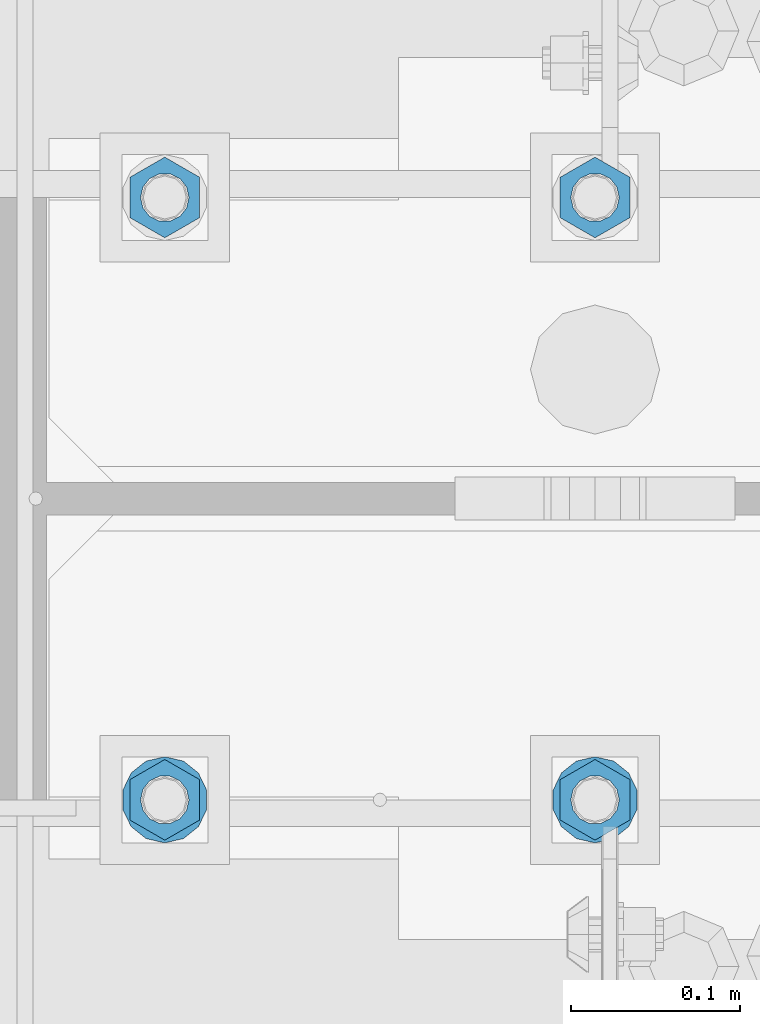
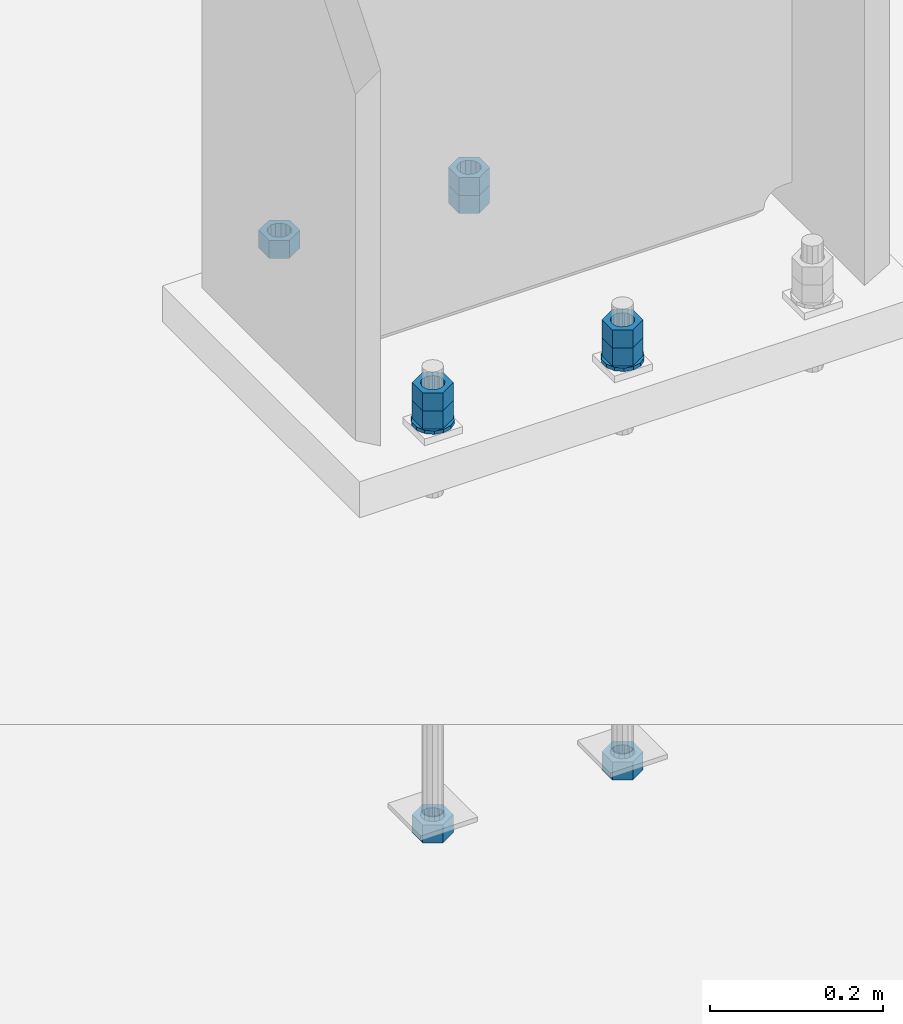
# One storey, part 1016 of 1763: 11 columns, 1 element without a shape of its own.
"""IFC2X3 building model written with IfcOpenShell, lengths in millimetres."""

from ifc_helpers import new_model, si_unit, frame, origin_with_axes, place, context, subcontext, project, spatial, faceted_brep, material, type_object, element, aggregate, save


model = new_model("IFC2X3")

# Units and contexts
model_context = context("Model", 3, precision=1e-05, world=origin_with_axes())
body_context = subcontext(model_context, "Body", "Model", "MODEL_VIEW")
ifc_project = project(units=[si_unit("LENGTHUNIT", "METRE", prefix="MILLI"), si_unit("AREAUNIT", "SQUARE_METRE"), si_unit("VOLUMEUNIT", "CUBIC_METRE"), si_unit("MASSUNIT", "GRAM", prefix="KILO"), si_unit("TIMEUNIT", "SECOND"), si_unit("PLANEANGLEUNIT", "RADIAN"), si_unit("SOLIDANGLEUNIT", "STERADIAN"), si_unit("THERMODYNAMICTEMPERATUREUNIT", "DEGREE_CELSIUS"), si_unit("LUMINOUSINTENSITYUNIT", "LUMEN")], contexts=[model_context])

# Site, building, storey
site_placement = place(None, origin_with_axes())
site = spatial("IfcSite", under=ifc_project, at=site_placement, CompositionType="ELEMENT")
building_placement = place(site_placement, origin_with_axes())
building = spatial("IfcBuilding", under=site, at=building_placement, Name="Undefined", CompositionType="ELEMENT")
storey_placement = place(building_placement, origin_with_axes())
storey = spatial("IfcBuildingStorey", under=building, at=storey_placement, Name="Undefined", CompositionType="ELEMENT", Elevation=0.0)

# Assembly, columns
assembly_placement = place(storey_placement, origin_with_axes())
assembly = element("IfcElementAssembly", 1, at=assembly_placement, inside=storey, Name="TEMPLATE", AssemblyPlace="NOTDEFINED", PredefinedType="RIGID_FRAME")
ifc_material_1 = material(Name="STEEL/A563")
column_type_1 = type_object("IfcColumnType", Name="1_HEAVY_HEX_NUT", PredefinedType="NOTDEFINED")
column_1_placement = place(assembly_placement, frame((-87375.4372736983, 51943.0, -150.812500000016), z_axis=(1.0, 0.0, 0.0), x_axis=(0.0, 0.0, -1.0)))
column_1 = element("IfcColumn", 2, at=column_1_placement, type_object=column_type_1, material=ifc_material_1, Name="NUT", ObjectType="1_HEAVY_HEX_NUT", context=body_context, shape_type="Brep", body=[
    faceted_brep([(0.0, -23.8099994659424, 0.0), (0.0, -11.9099998474121, -20.6200008392334), (25.4, -11.9099998474121, -20.6200008392334), (25.4, -23.8099994659424, 0.0), (0.0, 11.9099998474121, -20.6200008392334), (25.4, 11.9099998474121, -20.6200008392334), (0.0, 23.8099994659424, 0.0), (25.4, 23.8099994659424, 0.0), (0.0, 11.9099998474121, 20.6200008392334), (25.4, 11.9099998474121, 20.6200008392334), (0.0, -11.9099998474121, 20.6200008392334), (25.4, -11.9099998474121, 20.6200008392334), (0.0, 0.0, 14.289999961853), (0.0, 6.20019861543551, 12.8748450879575), (25.4, 6.20019861543551, 12.8748450879502), (25.4, 0.0, 14.289999961853), (0.0, 11.1723718546418, 8.90966924477834), (25.4, 11.1723718546418, 8.90966924477834), (0.0, 13.9317198278877, 3.17982413774735), (25.4, 13.9317198278877, 3.17982413774007), (0.0, 13.9317198278877, -3.17982413774735), (25.4, 13.9317198278877, -3.17982413774007), (0.0, 11.1723718546418, -8.90966924477834), (25.4, 11.1723718546418, -8.90966924477834), (0.0, 6.20019861543551, -12.8748450879575), (25.4, 6.20019861543551, -12.8748450879502), (0.0, 0.0, -14.289999961853), (25.4, 0.0, -14.289999961853), (0.0, -6.20019861543551, -12.8748450879575), (25.4, -6.20019861543551, -12.8748450879502), (0.0, -11.1723718546418, -8.90966924477834), (25.4, -11.1723718546418, -8.90966924477834), (0.0, -13.9317198278877, -3.17982413774735), (25.4, -13.9317198278877, -3.17982413774007), (0.0, -13.9317198278877, 3.17982413774735), (25.4, -13.9317198278877, 3.17982413774007), (0.0, -11.1723718546418, 8.90966924477834), (25.4, -11.1723718546418, 8.90966924477834), (0.0, -6.20019861543551, 12.8748450879575), (25.4, -6.20019861543551, 12.8748450879502)], [[[0, 1, 2, 3]], [[1, 4, 5, 2]], [[4, 6, 7, 5]], [[6, 8, 9, 7]], [[8, 10, 11, 9]], [[10, 0, 3, 11]], [[12, 13, 14, 15]], [[13, 16, 17, 14]], [[16, 18, 19, 17]], [[18, 20, 21, 19]], [[20, 22, 23, 21]], [[22, 24, 25, 23]], [[24, 26, 27, 25]], [[26, 28, 29, 27]], [[28, 30, 31, 29]], [[30, 32, 33, 31]], [[32, 34, 35, 33]], [[34, 36, 37, 35]], [[36, 38, 39, 37]], [[38, 12, 15, 39]], [[5, 7, 9, 11, 3, 2], [17, 19, 21, 23, 25, 27, 29, 31, 33, 35, 37, 39, 15, 14]], [[10, 8, 6, 4, 1, 0], [38, 36, 34, 32, 30, 28, 26, 24, 22, 20, 18, 16, 13, 12]]]),
])
column_2_placement = place(assembly_placement, frame((-87375.4372736983, 52298.6, -150.812500000016), z_axis=(-1.0, 0.0, 0.0), x_axis=(0.0, 0.0, -1.0)))
column_2 = element("IfcColumn", 3, at=column_2_placement, type_object=column_type_1, material=ifc_material_1, Name="NUT", ObjectType="1_HEAVY_HEX_NUT", context=body_context, shape_type="Brep", body=[
    faceted_brep([(0.0, -23.8099994659424, 0.0), (0.0, -11.9099998474121, -20.6200008392334), (25.4, -11.9099998474121, -20.6200008392334), (25.4, -23.8099994659424, 0.0), (0.0, 11.9099998474121, -20.6200008392334), (25.4, 11.9099998474121, -20.6200008392334), (0.0, 23.8099994659424, 0.0), (25.4, 23.8099994659424, 0.0), (0.0, 11.9099998474121, 20.6200008392334), (25.4, 11.9099998474121, 20.6200008392334), (0.0, -11.9099998474121, 20.6200008392334), (25.4, -11.9099998474121, 20.6200008392334), (0.0, 0.0, 14.289999961853), (0.0, 6.20019861543551, 12.8748450879575), (25.4, 6.20019861543551, 12.8748450879502), (25.4, 0.0, 14.289999961853), (0.0, 11.1723718546418, 8.90966924477834), (25.4, 11.1723718546418, 8.90966924477834), (0.0, 13.9317198278877, 3.17982413774735), (25.4, 13.9317198278877, 3.17982413774007), (0.0, 13.9317198278877, -3.17982413774735), (25.4, 13.9317198278877, -3.17982413774007), (0.0, 11.1723718546418, -8.90966924477834), (25.4, 11.1723718546418, -8.90966924477834), (0.0, 6.20019861543551, -12.8748450879575), (25.4, 6.20019861543551, -12.8748450879502), (0.0, 0.0, -14.289999961853), (25.4, 0.0, -14.289999961853), (0.0, -6.20019861543551, -12.8748450879575), (25.4, -6.20019861543551, -12.8748450879502), (0.0, -11.1723718546418, -8.90966924477834), (25.4, -11.1723718546418, -8.90966924477834), (0.0, -13.9317198278877, -3.17982413774735), (25.4, -13.9317198278877, -3.17982413774007), (0.0, -13.9317198278877, 3.17982413774735), (25.4, -13.9317198278877, 3.17982413774007), (0.0, -11.1723718546418, 8.90966924477834), (25.4, -11.1723718546418, 8.90966924477834), (0.0, -6.20019861543551, 12.8748450879575), (25.4, -6.20019861543551, 12.8748450879502)], [[[0, 1, 2, 3]], [[1, 4, 5, 2]], [[4, 6, 7, 5]], [[6, 8, 9, 7]], [[8, 10, 11, 9]], [[10, 0, 3, 11]], [[12, 13, 14, 15]], [[13, 16, 17, 14]], [[16, 18, 19, 17]], [[18, 20, 21, 19]], [[20, 22, 23, 21]], [[22, 24, 25, 23]], [[24, 26, 27, 25]], [[26, 28, 29, 27]], [[28, 30, 31, 29]], [[30, 32, 33, 31]], [[32, 34, 35, 33]], [[34, 36, 37, 35]], [[36, 38, 39, 37]], [[38, 12, 15, 39]], [[5, 7, 9, 11, 3, 2], [17, 19, 21, 23, 25, 27, 29, 31, 33, 35, 37, 39, 15, 14]], [[10, 8, 6, 4, 1, 0], [38, 36, 34, 32, 30, 28, 26, 24, 22, 20, 18, 16, 13, 12]]]),
])
column_3_placement = place(assembly_placement, frame((-87629.4372736983, 51943.0, -150.812500000016), z_axis=(1.0, 0.0, 0.0), x_axis=(0.0, 0.0, -1.0)))
column_3 = element("IfcColumn", 4, at=column_3_placement, type_object=column_type_1, material=ifc_material_1, Name="NUT", ObjectType="1_HEAVY_HEX_NUT", context=body_context, shape_type="Brep", body=[
    faceted_brep([(0.0, -23.8099994659424, 0.0), (0.0, -11.9099998474121, -20.6200008392334), (25.4, -11.9099998474121, -20.6200008392334), (25.4, -23.8099994659424, 0.0), (0.0, 11.9099998474121, -20.6200008392334), (25.4, 11.9099998474121, -20.6200008392334), (0.0, 23.8099994659424, 0.0), (25.4, 23.8099994659424, 0.0), (0.0, 11.9099998474121, 20.6200008392334), (25.4, 11.9099998474121, 20.6200008392334), (0.0, -11.9099998474121, 20.6200008392334), (25.4, -11.9099998474121, 20.6200008392334), (0.0, 0.0, 14.289999961853), (0.0, 6.20019861543551, 12.8748450879575), (25.4, 6.20019861543551, 12.8748450879502), (25.4, 0.0, 14.289999961853), (0.0, 11.1723718546418, 8.90966924477834), (25.4, 11.1723718546418, 8.90966924477834), (0.0, 13.9317198278877, 3.17982413774735), (25.4, 13.9317198278877, 3.17982413774007), (0.0, 13.9317198278877, -3.17982413774735), (25.4, 13.9317198278877, -3.17982413774007), (0.0, 11.1723718546418, -8.90966924477834), (25.4, 11.1723718546418, -8.90966924477834), (0.0, 6.20019861543551, -12.8748450879575), (25.4, 6.20019861543551, -12.8748450879502), (0.0, 0.0, -14.289999961853), (25.4, 0.0, -14.289999961853), (0.0, -6.20019861543551, -12.8748450879575), (25.4, -6.20019861543551, -12.8748450879502), (0.0, -11.1723718546418, -8.90966924477834), (25.4, -11.1723718546418, -8.90966924477834), (0.0, -13.9317198278877, -3.17982413774735), (25.4, -13.9317198278877, -3.17982413774007), (0.0, -13.9317198278877, 3.17982413774735), (25.4, -13.9317198278877, 3.17982413774007), (0.0, -11.1723718546418, 8.90966924477834), (25.4, -11.1723718546418, 8.90966924477834), (0.0, -6.20019861543551, 12.8748450879575), (25.4, -6.20019861543551, 12.8748450879502)], [[[0, 1, 2, 3]], [[1, 4, 5, 2]], [[4, 6, 7, 5]], [[6, 8, 9, 7]], [[8, 10, 11, 9]], [[10, 0, 3, 11]], [[12, 13, 14, 15]], [[13, 16, 17, 14]], [[16, 18, 19, 17]], [[18, 20, 21, 19]], [[20, 22, 23, 21]], [[22, 24, 25, 23]], [[24, 26, 27, 25]], [[26, 28, 29, 27]], [[28, 30, 31, 29]], [[30, 32, 33, 31]], [[32, 34, 35, 33]], [[34, 36, 37, 35]], [[36, 38, 39, 37]], [[38, 12, 15, 39]], [[5, 7, 9, 11, 3, 2], [17, 19, 21, 23, 25, 27, 29, 31, 33, 35, 37, 39, 15, 14]], [[10, 8, 6, 4, 1, 0], [38, 36, 34, 32, 30, 28, 26, 24, 22, 20, 18, 16, 13, 12]]]),
])
column_4_placement = place(assembly_placement, frame((-87629.4372736983, 52298.6, -150.812500000016), z_axis=(-1.0, 0.0, 0.0), x_axis=(0.0, 0.0, -1.0)))
column_4 = element("IfcColumn", 5, at=column_4_placement, type_object=column_type_1, material=ifc_material_1, Name="NUT", ObjectType="1_HEAVY_HEX_NUT", context=body_context, shape_type="Brep", body=[
    faceted_brep([(0.0, -23.8099994659424, 0.0), (0.0, -11.9099998474121, -20.6200008392334), (25.4, -11.9099998474121, -20.6200008392334), (25.4, -23.8099994659424, 0.0), (0.0, 11.9099998474121, -20.6200008392334), (25.4, 11.9099998474121, -20.6200008392334), (0.0, 23.8099994659424, 0.0), (25.4, 23.8099994659424, 0.0), (0.0, 11.9099998474121, 20.6200008392334), (25.4, 11.9099998474121, 20.6200008392334), (0.0, -11.9099998474121, 20.6200008392334), (25.4, -11.9099998474121, 20.6200008392334), (0.0, 0.0, 14.289999961853), (0.0, 6.20019861543551, 12.8748450879575), (25.4, 6.20019861543551, 12.8748450879502), (25.4, 0.0, 14.289999961853), (0.0, 11.1723718546418, 8.90966924477834), (25.4, 11.1723718546418, 8.90966924477834), (0.0, 13.9317198278877, 3.17982413774735), (25.4, 13.9317198278877, 3.17982413774007), (0.0, 13.9317198278877, -3.17982413774735), (25.4, 13.9317198278877, -3.17982413774007), (0.0, 11.1723718546418, -8.90966924477834), (25.4, 11.1723718546418, -8.90966924477834), (0.0, 6.20019861543551, -12.8748450879575), (25.4, 6.20019861543551, -12.8748450879502), (0.0, 0.0, -14.289999961853), (25.4, 0.0, -14.289999961853), (0.0, -6.20019861543551, -12.8748450879575), (25.4, -6.20019861543551, -12.8748450879502), (0.0, -11.1723718546418, -8.90966924477834), (25.4, -11.1723718546418, -8.90966924477834), (0.0, -13.9317198278877, -3.17982413774735), (25.4, -13.9317198278877, -3.17982413774007), (0.0, -13.9317198278877, 3.17982413774735), (25.4, -13.9317198278877, 3.17982413774007), (0.0, -11.1723718546418, 8.90966924477834), (25.4, -11.1723718546418, 8.90966924477834), (0.0, -6.20019861543551, 12.8748450879575), (25.4, -6.20019861543551, 12.8748450879502)], [[[0, 1, 2, 3]], [[1, 4, 5, 2]], [[4, 6, 7, 5]], [[6, 8, 9, 7]], [[8, 10, 11, 9]], [[10, 0, 3, 11]], [[12, 13, 14, 15]], [[13, 16, 17, 14]], [[16, 18, 19, 17]], [[18, 20, 21, 19]], [[20, 22, 23, 21]], [[22, 24, 25, 23]], [[24, 26, 27, 25]], [[26, 28, 29, 27]], [[28, 30, 31, 29]], [[30, 32, 33, 31]], [[32, 34, 35, 33]], [[34, 36, 37, 35]], [[36, 38, 39, 37]], [[38, 12, 15, 39]], [[5, 7, 9, 11, 3, 2], [17, 19, 21, 23, 25, 27, 29, 31, 33, 35, 37, 39, 15, 14]], [[10, 8, 6, 4, 1, 0], [38, 36, 34, 32, 30, 28, 26, 24, 22, 20, 18, 16, 13, 12]]]),
])
column_5_placement = place(assembly_placement, frame((-87375.4372736983, 51943.0, -176.212500000016), z_axis=(1.0, 0.0, 0.0), x_axis=(0.0, 0.0, -1.0)))
column_5 = element("IfcColumn", 6, at=column_5_placement, type_object=column_type_1, material=ifc_material_1, Name="NUT", ObjectType="1_HEAVY_HEX_NUT", context=body_context, shape_type="Brep", body=[
    faceted_brep([(0.0, -23.8099994659424, 0.0), (0.0, -11.9099998474121, -20.6200008392334), (25.4, -11.9099998474121, -20.6200008392334), (25.4, -23.8099994659424, 0.0), (0.0, 11.9099998474121, -20.6200008392334), (25.4, 11.9099998474121, -20.6200008392334), (0.0, 23.8099994659424, 0.0), (25.4, 23.8099994659424, 0.0), (0.0, 11.9099998474121, 20.6200008392334), (25.4, 11.9099998474121, 20.6200008392334), (0.0, -11.9099998474121, 20.6200008392334), (25.4, -11.9099998474121, 20.6200008392334), (0.0, 0.0, 14.289999961853), (0.0, 6.20019861543551, 12.8748450879575), (25.4, 6.20019861543551, 12.8748450879502), (25.4, 0.0, 14.289999961853), (0.0, 11.1723718546418, 8.90966924477834), (25.4, 11.1723718546418, 8.90966924477834), (0.0, 13.9317198278877, 3.17982413774735), (25.4, 13.9317198278877, 3.17982413774007), (0.0, 13.9317198278877, -3.17982413774735), (25.4, 13.9317198278877, -3.17982413774007), (0.0, 11.1723718546418, -8.90966924477834), (25.4, 11.1723718546418, -8.90966924477834), (0.0, 6.20019861543551, -12.8748450879575), (25.4, 6.20019861543551, -12.8748450879502), (0.0, 0.0, -14.289999961853), (25.4, 0.0, -14.289999961853), (0.0, -6.20019861543551, -12.8748450879575), (25.4, -6.20019861543551, -12.8748450879502), (0.0, -11.1723718546418, -8.90966924477834), (25.4, -11.1723718546418, -8.90966924477834), (0.0, -13.9317198278877, -3.17982413774735), (25.4, -13.9317198278877, -3.17982413774007), (0.0, -13.9317198278877, 3.17982413774735), (25.4, -13.9317198278877, 3.17982413774007), (0.0, -11.1723718546418, 8.90966924477834), (25.4, -11.1723718546418, 8.90966924477834), (0.0, -6.20019861543551, 12.8748450879575), (25.4, -6.20019861543551, 12.8748450879502)], [[[0, 1, 2, 3]], [[1, 4, 5, 2]], [[4, 6, 7, 5]], [[6, 8, 9, 7]], [[8, 10, 11, 9]], [[10, 0, 3, 11]], [[12, 13, 14, 15]], [[13, 16, 17, 14]], [[16, 18, 19, 17]], [[18, 20, 21, 19]], [[20, 22, 23, 21]], [[22, 24, 25, 23]], [[24, 26, 27, 25]], [[26, 28, 29, 27]], [[28, 30, 31, 29]], [[30, 32, 33, 31]], [[32, 34, 35, 33]], [[34, 36, 37, 35]], [[36, 38, 39, 37]], [[38, 12, 15, 39]], [[5, 7, 9, 11, 3, 2], [17, 19, 21, 23, 25, 27, 29, 31, 33, 35, 37, 39, 15, 14]], [[10, 8, 6, 4, 1, 0], [38, 36, 34, 32, 30, 28, 26, 24, 22, 20, 18, 16, 13, 12]]]),
])
column_6_placement = place(assembly_placement, frame((-87375.4372736983, 51943.0, -762.000000000016), z_axis=(1.0, 0.0, 0.0), x_axis=(0.0, 0.0, -1.0)))
column_6 = element("IfcColumn", 7, at=column_6_placement, type_object=column_type_1, material=ifc_material_1, Name="NUT", ObjectType="1_HEAVY_HEX_NUT", context=body_context, shape_type="Brep", body=[
    faceted_brep([(0.0, -23.8099994659424, 0.0), (0.0, -11.9099998474121, -20.6200008392334), (25.4, -11.9099998474121, -20.6200008392334), (25.4, -23.8099994659424, 0.0), (0.0, 11.9099998474121, -20.6200008392334), (25.4, 11.9099998474121, -20.6200008392334), (0.0, 23.8099994659424, 0.0), (25.4, 23.8099994659424, 0.0), (0.0, 11.9099998474121, 20.6200008392334), (25.4, 11.9099998474121, 20.6200008392334), (0.0, -11.9099998474121, 20.6200008392334), (25.4, -11.9099998474121, 20.6200008392334), (0.0, 0.0, 14.289999961853), (0.0, 6.20019861543551, 12.8748450879575), (25.4, 6.20019861543551, 12.8748450879502), (25.4, 0.0, 14.289999961853), (0.0, 11.1723718546418, 8.90966924477834), (25.4, 11.1723718546418, 8.90966924477834), (0.0, 13.9317198278877, 3.17982413774735), (25.4, 13.9317198278877, 3.17982413774007), (0.0, 13.9317198278877, -3.17982413774735), (25.4, 13.9317198278877, -3.17982413774007), (0.0, 11.1723718546418, -8.90966924477834), (25.4, 11.1723718546418, -8.90966924477834), (0.0, 6.20019861543551, -12.8748450879575), (25.4, 6.20019861543551, -12.8748450879502), (0.0, 0.0, -14.289999961853), (25.4, 0.0, -14.289999961853), (0.0, -6.20019861543551, -12.8748450879575), (25.4, -6.20019861543551, -12.8748450879502), (0.0, -11.1723718546418, -8.90966924477834), (25.4, -11.1723718546418, -8.90966924477834), (0.0, -13.9317198278877, -3.17982413774735), (25.4, -13.9317198278877, -3.17982413774007), (0.0, -13.9317198278877, 3.17982413774735), (25.4, -13.9317198278877, 3.17982413774007), (0.0, -11.1723718546418, 8.90966924477834), (25.4, -11.1723718546418, 8.90966924477834), (0.0, -6.20019861543551, 12.8748450879575), (25.4, -6.20019861543551, 12.8748450879502)], [[[0, 1, 2, 3]], [[1, 4, 5, 2]], [[4, 6, 7, 5]], [[6, 8, 9, 7]], [[8, 10, 11, 9]], [[10, 0, 3, 11]], [[12, 13, 14, 15]], [[13, 16, 17, 14]], [[16, 18, 19, 17]], [[18, 20, 21, 19]], [[20, 22, 23, 21]], [[22, 24, 25, 23]], [[24, 26, 27, 25]], [[26, 28, 29, 27]], [[28, 30, 31, 29]], [[30, 32, 33, 31]], [[32, 34, 35, 33]], [[34, 36, 37, 35]], [[36, 38, 39, 37]], [[38, 12, 15, 39]], [[5, 7, 9, 11, 3, 2], [17, 19, 21, 23, 25, 27, 29, 31, 33, 35, 37, 39, 15, 14]], [[10, 8, 6, 4, 1, 0], [38, 36, 34, 32, 30, 28, 26, 24, 22, 20, 18, 16, 13, 12]]]),
])
column_7_placement = place(assembly_placement, frame((-87375.4372736983, 52298.6, -176.212500000016), z_axis=(-1.0, 0.0, 0.0), x_axis=(0.0, 0.0, -1.0)))
column_7 = element("IfcColumn", 8, at=column_7_placement, type_object=column_type_1, material=ifc_material_1, Name="NUT", ObjectType="1_HEAVY_HEX_NUT", context=body_context, shape_type="Brep", body=[
    faceted_brep([(0.0, -23.8099994659424, 0.0), (0.0, -11.9099998474121, -20.6200008392334), (25.4, -11.9099998474121, -20.6200008392334), (25.4, -23.8099994659424, 0.0), (0.0, 11.9099998474121, -20.6200008392334), (25.4, 11.9099998474121, -20.6200008392334), (0.0, 23.8099994659424, 0.0), (25.4, 23.8099994659424, 0.0), (0.0, 11.9099998474121, 20.6200008392334), (25.4, 11.9099998474121, 20.6200008392334), (0.0, -11.9099998474121, 20.6200008392334), (25.4, -11.9099998474121, 20.6200008392334), (0.0, 0.0, 14.289999961853), (0.0, 6.20019861543551, 12.8748450879575), (25.4, 6.20019861543551, 12.8748450879502), (25.4, 0.0, 14.289999961853), (0.0, 11.1723718546418, 8.90966924477834), (25.4, 11.1723718546418, 8.90966924477834), (0.0, 13.9317198278877, 3.17982413774735), (25.4, 13.9317198278877, 3.17982413774007), (0.0, 13.9317198278877, -3.17982413774735), (25.4, 13.9317198278877, -3.17982413774007), (0.0, 11.1723718546418, -8.90966924477834), (25.4, 11.1723718546418, -8.90966924477834), (0.0, 6.20019861543551, -12.8748450879575), (25.4, 6.20019861543551, -12.8748450879502), (0.0, 0.0, -14.289999961853), (25.4, 0.0, -14.289999961853), (0.0, -6.20019861543551, -12.8748450879575), (25.4, -6.20019861543551, -12.8748450879502), (0.0, -11.1723718546418, -8.90966924477834), (25.4, -11.1723718546418, -8.90966924477834), (0.0, -13.9317198278877, -3.17982413774735), (25.4, -13.9317198278877, -3.17982413774007), (0.0, -13.9317198278877, 3.17982413774735), (25.4, -13.9317198278877, 3.17982413774007), (0.0, -11.1723718546418, 8.90966924477834), (25.4, -11.1723718546418, 8.90966924477834), (0.0, -6.20019861543551, 12.8748450879575), (25.4, -6.20019861543551, 12.8748450879502)], [[[0, 1, 2, 3]], [[1, 4, 5, 2]], [[4, 6, 7, 5]], [[6, 8, 9, 7]], [[8, 10, 11, 9]], [[10, 0, 3, 11]], [[12, 13, 14, 15]], [[13, 16, 17, 14]], [[16, 18, 19, 17]], [[18, 20, 21, 19]], [[20, 22, 23, 21]], [[22, 24, 25, 23]], [[24, 26, 27, 25]], [[26, 28, 29, 27]], [[28, 30, 31, 29]], [[30, 32, 33, 31]], [[32, 34, 35, 33]], [[34, 36, 37, 35]], [[36, 38, 39, 37]], [[38, 12, 15, 39]], [[5, 7, 9, 11, 3, 2], [17, 19, 21, 23, 25, 27, 29, 31, 33, 35, 37, 39, 15, 14]], [[10, 8, 6, 4, 1, 0], [38, 36, 34, 32, 30, 28, 26, 24, 22, 20, 18, 16, 13, 12]]]),
])
column_8_placement = place(assembly_placement, frame((-87629.4372736983, 51943.0, -176.212500000016), z_axis=(1.0, 0.0, 0.0), x_axis=(0.0, 0.0, -1.0)))
column_8 = element("IfcColumn", 9, at=column_8_placement, type_object=column_type_1, material=ifc_material_1, Name="NUT", ObjectType="1_HEAVY_HEX_NUT", context=body_context, shape_type="Brep", body=[
    faceted_brep([(0.0, -23.8099994659424, 0.0), (0.0, -11.9099998474121, -20.6200008392334), (25.4, -11.9099998474121, -20.6200008392334), (25.4, -23.8099994659424, 0.0), (0.0, 11.9099998474121, -20.6200008392334), (25.4, 11.9099998474121, -20.6200008392334), (0.0, 23.8099994659424, 0.0), (25.4, 23.8099994659424, 0.0), (0.0, 11.9099998474121, 20.6200008392334), (25.4, 11.9099998474121, 20.6200008392334), (0.0, -11.9099998474121, 20.6200008392334), (25.4, -11.9099998474121, 20.6200008392334), (0.0, 0.0, 14.289999961853), (0.0, 6.20019861543551, 12.8748450879575), (25.4, 6.20019861543551, 12.8748450879502), (25.4, 0.0, 14.289999961853), (0.0, 11.1723718546418, 8.90966924477834), (25.4, 11.1723718546418, 8.90966924477834), (0.0, 13.9317198278877, 3.17982413774735), (25.4, 13.9317198278877, 3.17982413774007), (0.0, 13.9317198278877, -3.17982413774735), (25.4, 13.9317198278877, -3.17982413774007), (0.0, 11.1723718546418, -8.90966924477834), (25.4, 11.1723718546418, -8.90966924477834), (0.0, 6.20019861543551, -12.8748450879575), (25.4, 6.20019861543551, -12.8748450879502), (0.0, 0.0, -14.289999961853), (25.4, 0.0, -14.289999961853), (0.0, -6.20019861543551, -12.8748450879575), (25.4, -6.20019861543551, -12.8748450879502), (0.0, -11.1723718546418, -8.90966924477834), (25.4, -11.1723718546418, -8.90966924477834), (0.0, -13.9317198278877, -3.17982413774735), (25.4, -13.9317198278877, -3.17982413774007), (0.0, -13.9317198278877, 3.17982413774735), (25.4, -13.9317198278877, 3.17982413774007), (0.0, -11.1723718546418, 8.90966924477834), (25.4, -11.1723718546418, 8.90966924477834), (0.0, -6.20019861543551, 12.8748450879575), (25.4, -6.20019861543551, 12.8748450879502)], [[[0, 1, 2, 3]], [[1, 4, 5, 2]], [[4, 6, 7, 5]], [[6, 8, 9, 7]], [[8, 10, 11, 9]], [[10, 0, 3, 11]], [[12, 13, 14, 15]], [[13, 16, 17, 14]], [[16, 18, 19, 17]], [[18, 20, 21, 19]], [[20, 22, 23, 21]], [[22, 24, 25, 23]], [[24, 26, 27, 25]], [[26, 28, 29, 27]], [[28, 30, 31, 29]], [[30, 32, 33, 31]], [[32, 34, 35, 33]], [[34, 36, 37, 35]], [[36, 38, 39, 37]], [[38, 12, 15, 39]], [[5, 7, 9, 11, 3, 2], [17, 19, 21, 23, 25, 27, 29, 31, 33, 35, 37, 39, 15, 14]], [[10, 8, 6, 4, 1, 0], [38, 36, 34, 32, 30, 28, 26, 24, 22, 20, 18, 16, 13, 12]]]),
])
column_9_placement = place(assembly_placement, frame((-87629.4372736983, 51943.0, -762.000000000016), z_axis=(1.0, 0.0, 0.0), x_axis=(0.0, 0.0, -1.0)))
column_9 = element("IfcColumn", 10, at=column_9_placement, type_object=column_type_1, material=ifc_material_1, Name="NUT", ObjectType="1_HEAVY_HEX_NUT", context=body_context, shape_type="Brep", body=[
    faceted_brep([(0.0, -23.8099994659424, 0.0), (0.0, -11.9099998474121, -20.6200008392334), (25.4, -11.9099998474121, -20.6200008392334), (25.4, -23.8099994659424, 0.0), (0.0, 11.9099998474121, -20.6200008392334), (25.4, 11.9099998474121, -20.6200008392334), (0.0, 23.8099994659424, 0.0), (25.4, 23.8099994659424, 0.0), (0.0, 11.9099998474121, 20.6200008392334), (25.4, 11.9099998474121, 20.6200008392334), (0.0, -11.9099998474121, 20.6200008392334), (25.4, -11.9099998474121, 20.6200008392334), (0.0, 0.0, 14.289999961853), (0.0, 6.20019861543551, 12.8748450879575), (25.4, 6.20019861543551, 12.8748450879502), (25.4, 0.0, 14.289999961853), (0.0, 11.1723718546418, 8.90966924477834), (25.4, 11.1723718546418, 8.90966924477834), (0.0, 13.9317198278877, 3.17982413774735), (25.4, 13.9317198278877, 3.17982413774007), (0.0, 13.9317198278877, -3.17982413774735), (25.4, 13.9317198278877, -3.17982413774007), (0.0, 11.1723718546418, -8.90966924477834), (25.4, 11.1723718546418, -8.90966924477834), (0.0, 6.20019861543551, -12.8748450879575), (25.4, 6.20019861543551, -12.8748450879502), (0.0, 0.0, -14.289999961853), (25.4, 0.0, -14.289999961853), (0.0, -6.20019861543551, -12.8748450879575), (25.4, -6.20019861543551, -12.8748450879502), (0.0, -11.1723718546418, -8.90966924477834), (25.4, -11.1723718546418, -8.90966924477834), (0.0, -13.9317198278877, -3.17982413774735), (25.4, -13.9317198278877, -3.17982413774007), (0.0, -13.9317198278877, 3.17982413774735), (25.4, -13.9317198278877, 3.17982413774007), (0.0, -11.1723718546418, 8.90966924477834), (25.4, -11.1723718546418, 8.90966924477834), (0.0, -6.20019861543551, 12.8748450879575), (25.4, -6.20019861543551, 12.8748450879502)], [[[0, 1, 2, 3]], [[1, 4, 5, 2]], [[4, 6, 7, 5]], [[6, 8, 9, 7]], [[8, 10, 11, 9]], [[10, 0, 3, 11]], [[12, 13, 14, 15]], [[13, 16, 17, 14]], [[16, 18, 19, 17]], [[18, 20, 21, 19]], [[20, 22, 23, 21]], [[22, 24, 25, 23]], [[24, 26, 27, 25]], [[26, 28, 29, 27]], [[28, 30, 31, 29]], [[30, 32, 33, 31]], [[32, 34, 35, 33]], [[34, 36, 37, 35]], [[36, 38, 39, 37]], [[38, 12, 15, 39]], [[5, 7, 9, 11, 3, 2], [17, 19, 21, 23, 25, 27, 29, 31, 33, 35, 37, 39, 15, 14]], [[10, 8, 6, 4, 1, 0], [38, 36, 34, 32, 30, 28, 26, 24, 22, 20, 18, 16, 13, 12]]]),
])
ifc_material_2 = material(Name="STEEL/F436")
column_type_2 = type_object("IfcColumnType", Name="1_WASHER", PredefinedType="NOTDEFINED")
column_10_placement = place(assembly_placement, frame((-87375.4372736983, 51943.0, -201.612500000016), z_axis=(1.0, 0.0, 0.0), x_axis=(0.0, 0.0, -1.0)))
column_10 = element("IfcColumn", 11, at=column_10_placement, type_object=column_type_2, material=ifc_material_2, Name="WASHER", ObjectType="1_WASHER", context=body_context, shape_type="Brep", body=[
    faceted_brep([(0.0, -25.4000000000015, 0.0), (0.0, -22.8846089010258, -11.0206468080723), (4.76249999999982, -22.8846089010258, -11.0206468080723), (4.76249999999982, -25.3999996185303, 0.0), (0.0, -15.8366407293724, -19.8585193564359), (4.76249999999982, -15.8366407293724, -19.8585193564359), (0.0, -5.65203163760452, -24.7631685975066), (4.76249999999982, -5.65203163760452, -24.7631685975066), (0.0, 5.65203163760452, -24.7631685975066), (4.76249999999982, 5.65203163760452, -24.7631685975066), (0.0, 15.8366407293724, -19.8585193564359), (4.76249999999982, 15.8366407293724, -19.8585193564359), (0.0, 22.8846089010258, -11.0206468080723), (4.76249999999982, 22.8846089010258, -11.0206468080723), (0.0, 25.4000000000015, 0.0), (4.76249999999982, 25.3999996185303, 0.0), (0.0, 22.8846089010258, 11.0206468080723), (4.76249999999982, 22.8846089010258, 11.0206468080723), (0.0, 15.8366407293724, 19.8585193564359), (4.76249999999982, 15.8366407293724, 19.8585193564359), (0.0, 5.65203163760452, 24.7631685975066), (4.76249999999982, 5.65203163760452, 24.7631685975066), (0.0, -5.65203163760452, 24.7631685975066), (4.76249999999982, -5.65203163760452, 24.7631685975066), (0.0, -15.8366407293724, 19.8585193564359), (4.76249999999982, -15.8366407293724, 19.8585193564359), (0.0, -22.8846089010258, 11.0206468080723), (4.76249999999982, -22.8846089010258, 11.0206468080723), (0.0, 0.0, 14.289999961853), (0.0, 6.20019861543551, 12.8748450879575), (4.76249999999982, 6.20019861543551, 12.8748450879502), (4.76249999999982, 0.0, 14.289999961853), (0.0, 11.1723718546418, 8.90966924477834), (4.76249999999982, 11.1723718546418, 8.90966924477834), (0.0, 13.9317198278877, 3.17982413774735), (4.76249999999982, 13.9317198278877, 3.17982413774007), (0.0, 13.9317198278877, -3.17982413774735), (4.76249999999982, 13.9317198278877, -3.17982413774007), (0.0, 11.1723718546418, -8.90966924477834), (4.76249999999982, 11.1723718546418, -8.90966924477834), (0.0, 6.20019861543551, -12.8748450879575), (4.76249999999982, 6.20019861543551, -12.8748450879502), (0.0, 0.0, -14.289999961853), (4.76249999999982, 0.0, -14.289999961853), (0.0, -6.20019861543551, -12.8748450879575), (4.76249999999982, -6.20019861543551, -12.8748450879502), (0.0, -11.1723718546418, -8.90966924477834), (4.76249999999982, -11.1723718546418, -8.90966924477834), (0.0, -13.9317198278877, -3.17982413774735), (4.76249999999982, -13.9317198278877, -3.17982413774007), (0.0, -13.9317198278877, 3.17982413774735), (4.76249999999982, -13.9317198278877, 3.17982413774007), (0.0, -11.1723718546418, 8.90966924477834), (4.76249999999982, -11.1723718546418, 8.90966924477834), (0.0, -6.20019861543551, 12.8748450879575), (4.76249999999982, -6.20019861543551, 12.8748450879502)], [[[0, 1, 2, 3]], [[1, 4, 5, 2]], [[4, 6, 7, 5]], [[6, 8, 9, 7]], [[8, 10, 11, 9]], [[10, 12, 13, 11]], [[12, 14, 15, 13]], [[14, 16, 17, 15]], [[16, 18, 19, 17]], [[18, 20, 21, 19]], [[20, 22, 23, 21]], [[22, 24, 25, 23]], [[24, 26, 27, 25]], [[26, 0, 3, 27]], [[28, 29, 30, 31]], [[29, 32, 33, 30]], [[32, 34, 35, 33]], [[34, 36, 37, 35]], [[36, 38, 39, 37]], [[38, 40, 41, 39]], [[40, 42, 43, 41]], [[42, 44, 45, 43]], [[44, 46, 47, 45]], [[46, 48, 49, 47]], [[48, 50, 51, 49]], [[50, 52, 53, 51]], [[52, 54, 55, 53]], [[54, 28, 31, 55]], [[5, 7, 9, 11, 13, 15, 17, 19, 21, 23, 25, 27, 3, 2], [33, 35, 37, 39, 41, 43, 45, 47, 49, 51, 53, 55, 31, 30]], [[26, 24, 22, 20, 18, 16, 14, 12, 10, 8, 6, 4, 1, 0], [54, 52, 50, 48, 46, 44, 42, 40, 38, 36, 34, 32, 29, 28]]]),
])
column_11_placement = place(assembly_placement, frame((-87629.4372736983, 51943.0, -201.612500000016), z_axis=(1.0, 0.0, 0.0), x_axis=(0.0, 0.0, -1.0)))
column_11 = element("IfcColumn", 12, at=column_11_placement, type_object=column_type_2, material=ifc_material_2, Name="WASHER", ObjectType="1_WASHER", context=body_context, shape_type="Brep", body=[
    faceted_brep([(0.0, -25.4000000000015, 0.0), (0.0, -22.8846089010258, -11.0206468080723), (4.76249999999982, -22.8846089010258, -11.0206468080723), (4.76249999999982, -25.3999996185303, 0.0), (0.0, -15.8366407293724, -19.8585193564359), (4.76249999999982, -15.8366407293724, -19.8585193564359), (0.0, -5.65203163760452, -24.7631685975066), (4.76249999999982, -5.65203163760452, -24.7631685975066), (0.0, 5.65203163760452, -24.7631685975066), (4.76249999999982, 5.65203163760452, -24.7631685975066), (0.0, 15.8366407293724, -19.8585193564359), (4.76249999999982, 15.8366407293724, -19.8585193564359), (0.0, 22.8846089010258, -11.0206468080723), (4.76249999999982, 22.8846089010258, -11.0206468080723), (0.0, 25.4000000000015, 0.0), (4.76249999999982, 25.3999996185303, 0.0), (0.0, 22.8846089010258, 11.0206468080723), (4.76249999999982, 22.8846089010258, 11.0206468080723), (0.0, 15.8366407293724, 19.8585193564359), (4.76249999999982, 15.8366407293724, 19.8585193564359), (0.0, 5.65203163760452, 24.7631685975066), (4.76249999999982, 5.65203163760452, 24.7631685975066), (0.0, -5.65203163760452, 24.7631685975066), (4.76249999999982, -5.65203163760452, 24.7631685975066), (0.0, -15.8366407293724, 19.8585193564359), (4.76249999999982, -15.8366407293724, 19.8585193564359), (0.0, -22.8846089010258, 11.0206468080723), (4.76249999999982, -22.8846089010258, 11.0206468080723), (0.0, 0.0, 14.289999961853), (0.0, 6.20019861543551, 12.8748450879575), (4.76249999999982, 6.20019861543551, 12.8748450879502), (4.76249999999982, 0.0, 14.289999961853), (0.0, 11.1723718546418, 8.90966924477834), (4.76249999999982, 11.1723718546418, 8.90966924477834), (0.0, 13.9317198278877, 3.17982413774735), (4.76249999999982, 13.9317198278877, 3.17982413774007), (0.0, 13.9317198278877, -3.17982413774735), (4.76249999999982, 13.9317198278877, -3.17982413774007), (0.0, 11.1723718546418, -8.90966924477834), (4.76249999999982, 11.1723718546418, -8.90966924477834), (0.0, 6.20019861543551, -12.8748450879575), (4.76249999999982, 6.20019861543551, -12.8748450879502), (0.0, 0.0, -14.289999961853), (4.76249999999982, 0.0, -14.289999961853), (0.0, -6.20019861543551, -12.8748450879575), (4.76249999999982, -6.20019861543551, -12.8748450879502), (0.0, -11.1723718546418, -8.90966924477834), (4.76249999999982, -11.1723718546418, -8.90966924477834), (0.0, -13.9317198278877, -3.17982413774735), (4.76249999999982, -13.9317198278877, -3.17982413774007), (0.0, -13.9317198278877, 3.17982413774735), (4.76249999999982, -13.9317198278877, 3.17982413774007), (0.0, -11.1723718546418, 8.90966924477834), (4.76249999999982, -11.1723718546418, 8.90966924477834), (0.0, -6.20019861543551, 12.8748450879575), (4.76249999999982, -6.20019861543551, 12.8748450879502)], [[[0, 1, 2, 3]], [[1, 4, 5, 2]], [[4, 6, 7, 5]], [[6, 8, 9, 7]], [[8, 10, 11, 9]], [[10, 12, 13, 11]], [[12, 14, 15, 13]], [[14, 16, 17, 15]], [[16, 18, 19, 17]], [[18, 20, 21, 19]], [[20, 22, 23, 21]], [[22, 24, 25, 23]], [[24, 26, 27, 25]], [[26, 0, 3, 27]], [[28, 29, 30, 31]], [[29, 32, 33, 30]], [[32, 34, 35, 33]], [[34, 36, 37, 35]], [[36, 38, 39, 37]], [[38, 40, 41, 39]], [[40, 42, 43, 41]], [[42, 44, 45, 43]], [[44, 46, 47, 45]], [[46, 48, 49, 47]], [[48, 50, 51, 49]], [[50, 52, 53, 51]], [[52, 54, 55, 53]], [[54, 28, 31, 55]], [[5, 7, 9, 11, 13, 15, 17, 19, 21, 23, 25, 27, 3, 2], [33, 35, 37, 39, 41, 43, 45, 47, 49, 51, 53, 55, 31, 30]], [[26, 24, 22, 20, 18, 16, 14, 12, 10, 8, 6, 4, 1, 0], [54, 52, 50, 48, 46, 44, 42, 40, 38, 36, 34, 32, 29, 28]]]),
])
aggregate(assembly, [column_1, column_2, column_3, column_4, column_5, column_10, column_6, column_7, column_8, column_11, column_9])

save(model, "model.ifc")
